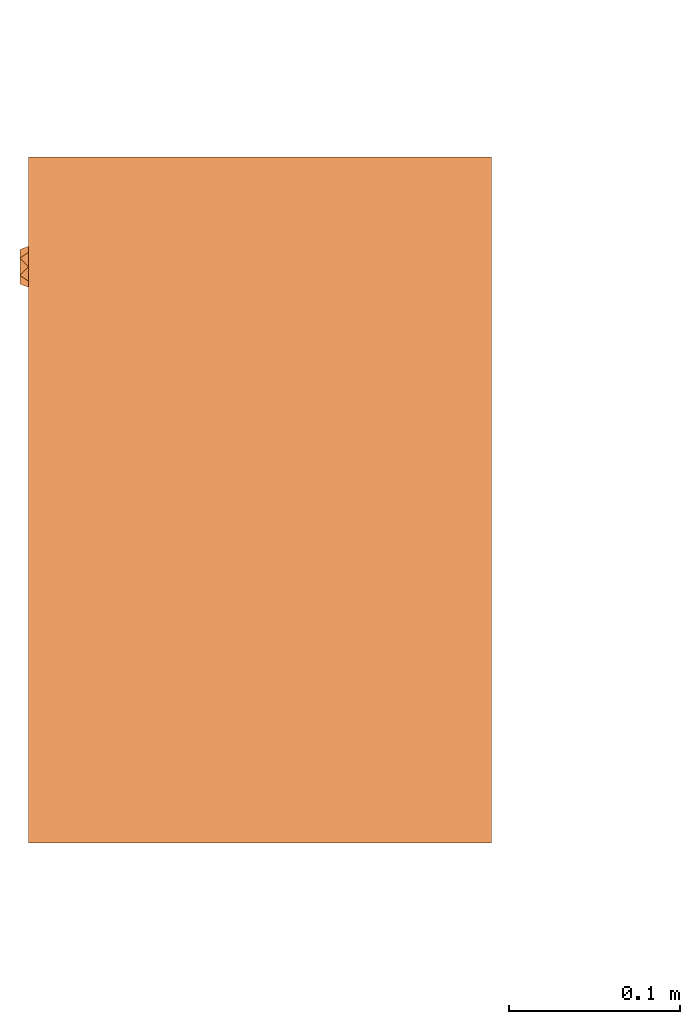
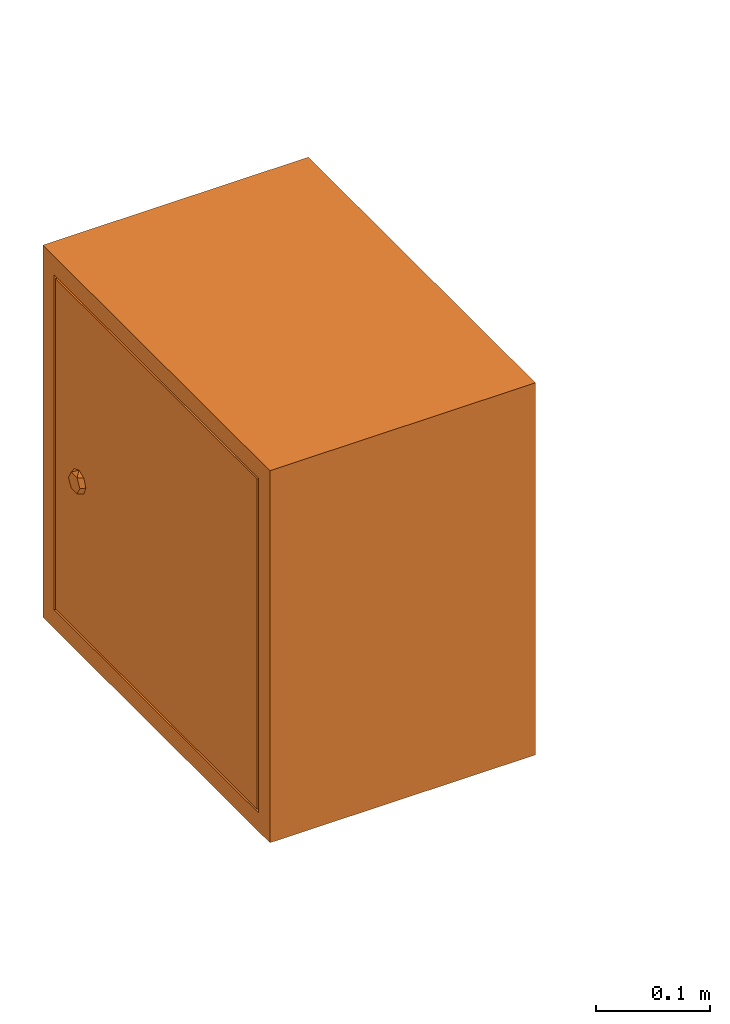
# One storey, part 3 of 3: 1 proxy.
"""IFC2X3 building model written with IfcOpenShell, lengths in millimetres."""

from ifc_helpers import new_model, entity, si_unit, converted_unit, derived_unit, direction, frame, origin, place, context, subcontext, project, spatial, faceted_brep, source, transform, mapped, material, material_list, type_object, type_shapes, element, save


model = new_model("IFC2X3")

# Units and contexts
model_context = context("Model", 3, precision=0.01, world=origin(), true_north=direction((6.12303176911189e-17, 1.0)))
body_context = subcontext(model_context, "Body", "Model", "MODEL_VIEW")
ifc_project = project(units=[si_unit("LENGTHUNIT", "METRE", prefix="MILLI"), si_unit("AREAUNIT", "SQUARE_METRE"), si_unit("VOLUMEUNIT", "CUBIC_METRE"), converted_unit("PLANEANGLEUNIT", "DEGREE", entity("IfcRatioMeasure", 0.0174532925199433), si_unit("PLANEANGLEUNIT", "RADIAN"), dimensions=[0, 0, 0, 0, 0, 0, 0]), si_unit("MASSUNIT", "GRAM", prefix="KILO"), derived_unit("MASSDENSITYUNIT", [(si_unit("MASSUNIT", "GRAM", prefix="KILO"), 1), (si_unit("LENGTHUNIT", "METRE"), -3)]), derived_unit("MOMENTOFINERTIAUNIT", [(si_unit("LENGTHUNIT", "METRE"), 4)]), si_unit("TIMEUNIT", "SECOND"), si_unit("FREQUENCYUNIT", "HERTZ"), si_unit("THERMODYNAMICTEMPERATUREUNIT", "DEGREE_CELSIUS"), derived_unit("THERMALTRANSMITTANCEUNIT", [(si_unit("MASSUNIT", "GRAM", prefix="KILO"), 1), (si_unit("THERMODYNAMICTEMPERATUREUNIT", "KELVIN"), -1), (si_unit("TIMEUNIT", "SECOND"), -3)]), derived_unit("VOLUMETRICFLOWRATEUNIT", [(si_unit("LENGTHUNIT", "METRE"), 3), (si_unit("TIMEUNIT", "SECOND"), -1)]), derived_unit("MASSFLOWRATEUNIT", [(si_unit("MASSUNIT", "GRAM", prefix="KILO"), 1), (si_unit("TIMEUNIT", "SECOND"), -1)]), derived_unit("ROTATIONALFREQUENCYUNIT", [(si_unit("TIMEUNIT", "SECOND"), -1)]), si_unit("ELECTRICCURRENTUNIT", "AMPERE"), si_unit("ELECTRICVOLTAGEUNIT", "VOLT"), si_unit("POWERUNIT", "WATT"), si_unit("FORCEUNIT", "NEWTON", prefix="KILO"), si_unit("ILLUMINANCEUNIT", "LUX"), si_unit("LUMINOUSFLUXUNIT", "LUMEN"), si_unit("LUMINOUSINTENSITYUNIT", "CANDELA"), derived_unit("USERDEFINED", [(si_unit("MASSUNIT", "GRAM", prefix="KILO"), -1), (si_unit("LENGTHUNIT", "METRE"), -2), (si_unit("TIMEUNIT", "SECOND"), 3), (si_unit("LUMINOUSFLUXUNIT", "LUMEN"), 1)]), derived_unit("LINEARVELOCITYUNIT", [(si_unit("LENGTHUNIT", "METRE"), 1), (si_unit("TIMEUNIT", "SECOND"), -1)]), si_unit("PRESSUREUNIT", "PASCAL"), derived_unit("USERDEFINED", [(si_unit("LENGTHUNIT", "METRE"), -2), (si_unit("MASSUNIT", "GRAM", prefix="KILO"), 1), (si_unit("TIMEUNIT", "SECOND"), -2)]), derived_unit("LINEARFORCEUNIT", [(si_unit("MASSUNIT", "GRAM", prefix="KILO"), 1), (si_unit("LENGTHUNIT", "METRE"), 1), (si_unit("TIMEUNIT", "SECOND"), -2), (si_unit("LENGTHUNIT", "METRE"), -1)]), derived_unit("PLANARFORCEUNIT", [(si_unit("MASSUNIT", "GRAM", prefix="KILO"), 1), (si_unit("LENGTHUNIT", "METRE"), 1), (si_unit("TIMEUNIT", "SECOND"), -2), (si_unit("LENGTHUNIT", "METRE"), -2)])], contexts=[model_context])

# Site, building, storey
site_placement = place(None, frame((0.0, 2493.83037508239, 0.0)))
site = spatial("IfcSite", under=ifc_project, at=site_placement, CompositionType="ELEMENT")
building_placement = place(site_placement, origin())
building = spatial("IfcBuilding", under=site, at=building_placement, CompositionType="ELEMENT")
storey_placement = place(building_placement, origin())
storey = spatial("IfcBuildingStorey", under=building, at=storey_placement, Name="01", CompositionType="ELEMENT", Elevation=0.0)

# Proxy
ifc_material_1 = material()
ifc_material_2 = material(Name="RBZ_")
ifc_material_list = material_list([ifc_material_1, ifc_material_2])
building_element_proxy_type = type_object("IfcBuildingElementProxyType", PredefinedType="NOTDEFINED", material=ifc_material_1)
shared_shape = source(origin(), body_context, "Body", "Brep", [
    faceted_brep([(348.066047820178, 270.0, 184.812766074716), (344.550721329073, 270.0, 176.326017183723), (346.146727645, 275.0, 184.812766074716), (341.10535004154, 275.0, 176.080843925383), (336.06397243808, 270.0, 172.810690692619), (327.577223547088, 270.0, 176.326017183723), (331.02259483462, 275.0, 176.080843925383), (325.98121723116, 275.0, 184.812766074716), (324.061897055983, 270.0, 184.812766074716), (327.577223547088, 270.0, 193.299514965709), (331.02259483462, 275.0, 193.544688224048), (336.06397243808, 270.0, 196.814841456813), (344.550721329073, 270.0, 193.299514965709), (341.10535004154, 275.0, 193.544688224048), (336.06397243808, 270.0, 184.812766074716), (336.063972438081, 275.0, 184.812766074716)], [[[0, 1, 2]], [[3, 2, 1]], [[1, 4, 3]], [[4, 5, 6]], [[5, 7, 6]], [[7, 5, 8]], [[4, 6, 3]], [[8, 9, 7]], [[10, 7, 9]], [[9, 11, 10]], [[11, 12, 13]], [[12, 2, 13]], [[2, 12, 0]], [[11, 13, 10]], [[5, 14, 8]], [[4, 14, 5]], [[4, 1, 14]], [[0, 14, 1]], [[0, 12, 14]], [[11, 14, 12]], [[11, 9, 14]], [[9, 8, 14]], [[6, 7, 15]], [[15, 3, 6]], [[7, 10, 15]], [[13, 15, 10]], [[15, 13, 2]], [[15, 2, 3]]]),
    faceted_brep([(0.0, 270.0, 400.0), (400.0, 270.0, 400.0), (400.0, 270.0, 0.0), (0.0, 270.0, 0.0), (380.0, 270.0, 380.0), (20.0, 270.0, 380.0), (20.0, 270.0, 20.0), (380.0, 270.0, 20.0), (0.0, 0.0, 400.0), (0.0, 0.0, 0.0), (400.0, 0.0, 0.0), (400.0, 0.0, 400.0), (20.0, 260.0, 380.0), (380.0, 260.0, 380.0), (380.0, 260.0, 20.0), (20.0, 260.0, 20.0), (377.5, 260.0, 377.500000000002), (22.4999999999994, 260.0, 377.500000000001), (22.5000000000005, 260.0, 22.5), (377.500000000001, 260.0, 22.5000000000012), (377.5, 270.0, 377.500000000002), (22.4999999999994, 270.0, 377.500000000001), (22.5000000000005, 270.0, 22.5), (377.500000000001, 270.0, 22.5000000000012)], [[[0, 1, 2, 3], [4, 5, 6, 7]], [[8, 9, 10, 11]], [[1, 0, 8, 11]], [[2, 1, 11, 10]], [[3, 2, 10, 9]], [[0, 3, 9, 8]], [[12, 13, 14, 15], [16, 17, 18, 19]], [[13, 12, 5, 4]], [[14, 13, 4, 7]], [[15, 14, 7, 6]], [[12, 15, 6, 5]], [[17, 16, 20, 21]], [[18, 17, 21, 22]], [[19, 18, 22, 23]], [[16, 19, 23, 20]], [[21, 20, 23, 22]]]),
])
type_shapes(building_element_proxy_type, [shared_shape])
proxy_placement = place(storey_placement, frame((44470.0018798833, 4231.16962506053, 1095.0), z_axis=(0.0, 0.0, 1.0), x_axis=(0.0, 1.0, 0.0)))
element("IfcBuildingElementProxy", 1, at=proxy_placement, inside=storey, type_object=building_element_proxy_type, material=ifc_material_list, context=body_context, shape_type="MappedRepresentation", body=[
    mapped(shared_shape, transform((0.0, 0.0, 0.0), scale=1.0)),
])

save(model, "model.ifc")
